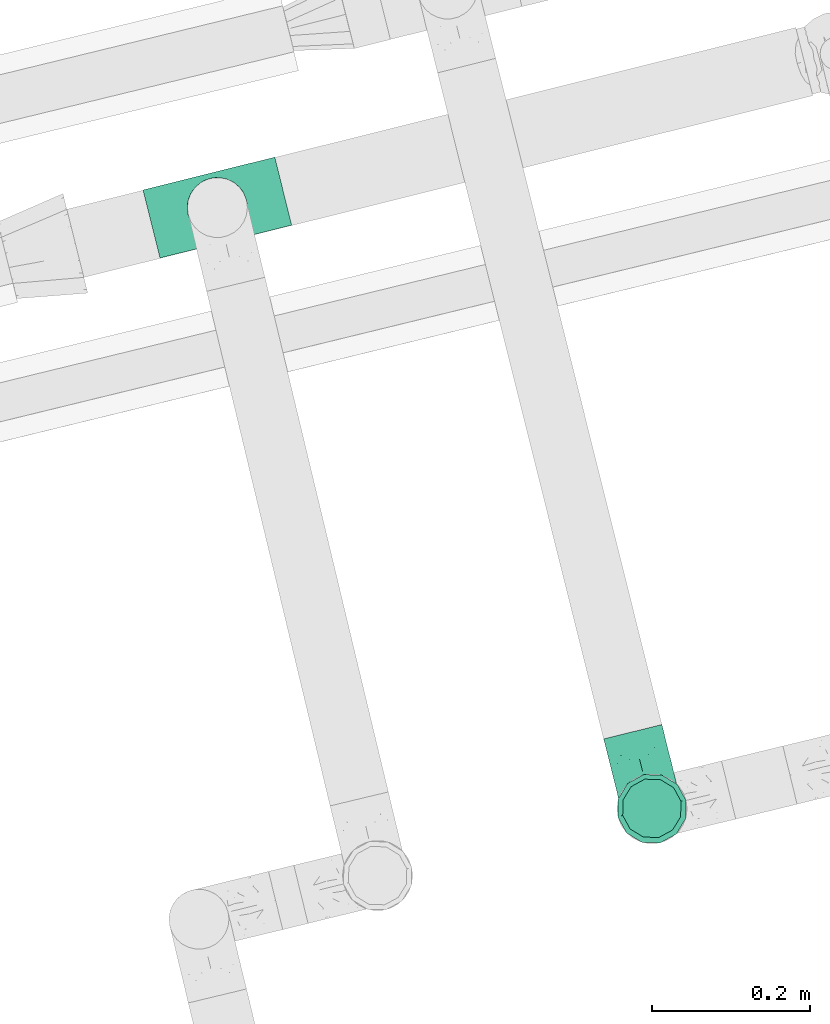
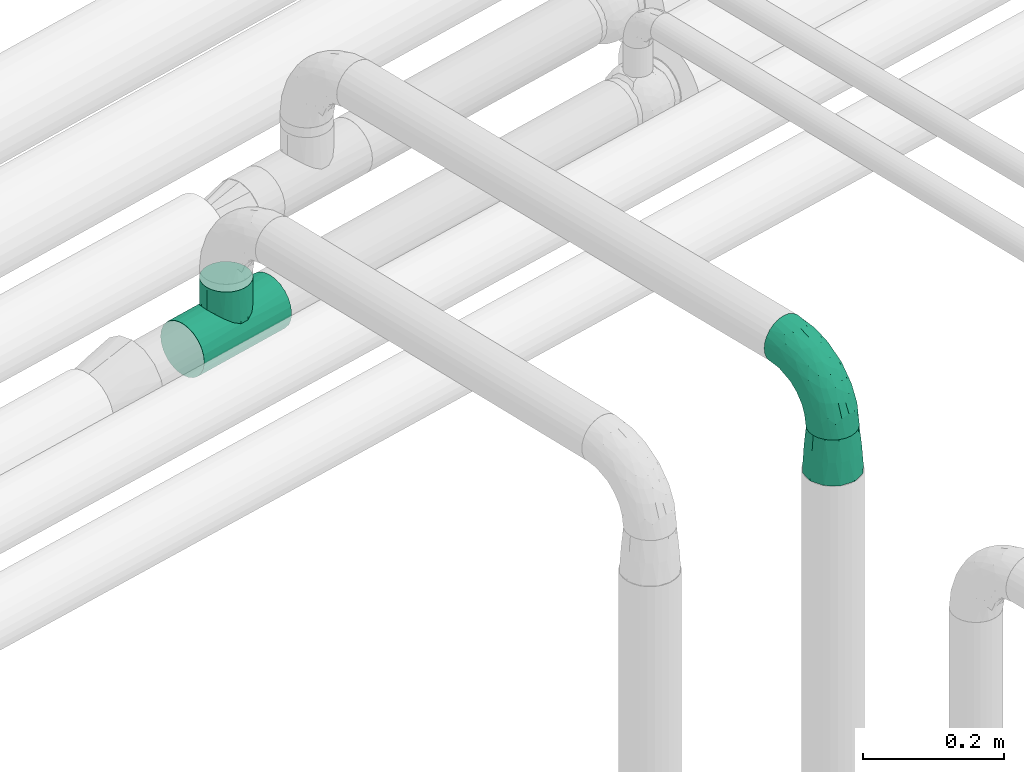
# One storey, part 86 of 93: 3 flow fittings.
"""IFC2X3 building model written with IfcOpenShell, lengths in millimetres."""

from ifc_helpers import new_model, entity, si_unit, converted_unit, derived_unit, direction, frame, origin, place, context, subcontext, project, spatial, faceted_brep, source, transform, mapped, material, type_object, type_shapes, element, save


model = new_model("IFC2X3")

# Units and contexts
model_context = context("Model", 3, precision=0.01, world=origin(), true_north=direction((6.12303176911189e-17, 1.0)))
body_context = subcontext(model_context, "Body", "Model", "MODEL_VIEW")
ifc_project = project(units=[si_unit("LENGTHUNIT", "METRE", prefix="MILLI"), si_unit("AREAUNIT", "SQUARE_METRE"), si_unit("VOLUMEUNIT", "CUBIC_METRE"), converted_unit("PLANEANGLEUNIT", "DEGREE", entity("IfcRatioMeasure", 0.0174532925199433), si_unit("PLANEANGLEUNIT", "RADIAN"), dimensions=[0, 0, 0, 0, 0, 0, 0]), si_unit("MASSUNIT", "GRAM", prefix="KILO"), derived_unit("MASSDENSITYUNIT", [(si_unit("MASSUNIT", "GRAM", prefix="KILO"), 1), (si_unit("LENGTHUNIT", "METRE"), -3)]), derived_unit("MOMENTOFINERTIAUNIT", [(si_unit("LENGTHUNIT", "METRE"), 4)]), si_unit("TIMEUNIT", "SECOND"), si_unit("FREQUENCYUNIT", "HERTZ"), si_unit("THERMODYNAMICTEMPERATUREUNIT", "DEGREE_CELSIUS"), derived_unit("THERMALTRANSMITTANCEUNIT", [(si_unit("MASSUNIT", "GRAM", prefix="KILO"), 1), (si_unit("THERMODYNAMICTEMPERATUREUNIT", "KELVIN"), -1), (si_unit("TIMEUNIT", "SECOND"), -3)]), derived_unit("VOLUMETRICFLOWRATEUNIT", [(si_unit("LENGTHUNIT", "METRE"), 3), (si_unit("TIMEUNIT", "SECOND"), -1)]), derived_unit("MASSFLOWRATEUNIT", [(si_unit("MASSUNIT", "GRAM", prefix="KILO"), 1), (si_unit("TIMEUNIT", "SECOND"), -1)]), derived_unit("ROTATIONALFREQUENCYUNIT", [(si_unit("TIMEUNIT", "SECOND"), -1)]), si_unit("ELECTRICCURRENTUNIT", "AMPERE"), si_unit("ELECTRICVOLTAGEUNIT", "VOLT"), si_unit("POWERUNIT", "WATT"), si_unit("FORCEUNIT", "NEWTON", prefix="KILO"), si_unit("ILLUMINANCEUNIT", "LUX"), si_unit("LUMINOUSFLUXUNIT", "LUMEN"), si_unit("LUMINOUSINTENSITYUNIT", "CANDELA"), derived_unit("USERDEFINED", [(si_unit("MASSUNIT", "GRAM", prefix="KILO"), -1), (si_unit("LENGTHUNIT", "METRE"), -2), (si_unit("TIMEUNIT", "SECOND"), 3), (si_unit("LUMINOUSFLUXUNIT", "LUMEN"), 1)]), derived_unit("LINEARVELOCITYUNIT", [(si_unit("LENGTHUNIT", "METRE"), 1), (si_unit("TIMEUNIT", "SECOND"), -1)]), si_unit("PRESSUREUNIT", "PASCAL"), derived_unit("USERDEFINED", [(si_unit("LENGTHUNIT", "METRE"), -2), (si_unit("MASSUNIT", "GRAM", prefix="KILO"), 1), (si_unit("TIMEUNIT", "SECOND"), -2)]), derived_unit("LINEARFORCEUNIT", [(si_unit("MASSUNIT", "GRAM", prefix="KILO"), 1), (si_unit("LENGTHUNIT", "METRE"), 1), (si_unit("TIMEUNIT", "SECOND"), -2), (si_unit("LENGTHUNIT", "METRE"), -1)]), derived_unit("PLANARFORCEUNIT", [(si_unit("MASSUNIT", "GRAM", prefix="KILO"), 1), (si_unit("LENGTHUNIT", "METRE"), 1), (si_unit("TIMEUNIT", "SECOND"), -2), (si_unit("LENGTHUNIT", "METRE"), -2)])], contexts=[model_context])

# Site, building, storey
site_placement = place(None, origin())
site = spatial("IfcSite", under=ifc_project, at=site_placement, CompositionType="ELEMENT")
building_placement = place(site_placement, origin())
building = spatial("IfcBuilding", under=site, at=building_placement, CompositionType="ELEMENT")
storey_placement = place(building_placement, frame((0.0, 0.0, -4200.0)))
storey = spatial("IfcBuildingStorey", under=building, at=storey_placement, CompositionType="ELEMENT", Elevation=-4200.0)

# Flow fittings
ifc_material = material()
pipe_fitting_type_1 = type_object("IfcPipeFittingType", Name="ADSK_2", PredefinedType="NOTDEFINED", material=ifc_material)
shared_shape_1 = source(origin(), body_context, "Body", "Brep", [
    faceted_brep([(-100.0, 19.0, -32.91), (-100.0, 9.84, -36.71), (-100.0, 0.0, -38.0), (-100.0, -9.84, -36.71), (-100.0, -19.0, -32.91), (-100.0, -26.87, -26.87), (-100.0, -32.91, -19.0), (-100.0, -36.71, -9.84), (-100.0, -38.0, 0.0), (-100.0, -36.71, 9.84), (-100.0, -32.91, 19.0), (-100.0, -26.87, 26.87), (-100.0, -19.0, 32.91), (-100.0, -9.84, 36.71), (-100.0, 0.0, 38.0), (-100.0, 9.84, 36.71), (-100.0, 19.0, 32.91), (-100.0, 26.87, 26.87), (-100.0, 32.91, 19.0), (-100.0, 36.71, 9.84), (-100.0, 38.0, 0.0), (-100.0, 36.71, -9.84), (-100.0, 32.91, -19.0), (-100.0, 26.87, -26.87), (-9.83, 100.0, -36.71), (-19.0, 100.0, -32.91), (-26.87, 100.0, -26.87), (-32.91, 100.0, -19.0), (-36.7, 100.0, -9.84), (-38.0, 100.0, 0.0), (-36.7, 100.0, 9.84), (-32.91, 100.0, 19.0), (-26.87, 100.0, 26.87), (-19.0, 100.0, 32.91), (-9.83, 100.0, 36.71), (0.0, 100.0, 38.0), (9.84, 100.0, 36.71), (19.0, 100.0, 32.91), (26.87, 100.0, 26.87), (32.91, 100.0, 19.0), (36.71, 100.0, 9.84), (38.0, 100.0, 0.0), (36.71, 100.0, -9.84), (32.91, 100.0, -19.0), (26.87, 100.0, -26.87), (19.0, 100.0, -32.91), (9.84, 100.0, -36.71), (0.0, 100.0, -38.0), (-40.69, 71.44, 16.62), (-81.22, -35.53, 0.0), (-67.52, -31.95, 12.5), (-8.97, -2.95, 6.59), (-11.71, -2.76, 13.62), (-24.68, -14.61, 8.04), (-64.28, -33.3, 0.0), (-83.72, 23.85, 30.89), (-76.19, 33.07, 24.6), (-74.12, -28.58, 21.76), (13.92, 43.47, 26.56), (5.03, 42.28, 32.41), (2.17, 22.78, 25.61), (20.11, 65.77, 28.71), (-65.77, -20.11, 28.71), (-74.23, -13.22, 34.41), (-44.44, -24.14, 12.16), (-47.64, -26.4, 0.0), (-31.0, -19.51, 0.0), (-54.86, 48.59, 21.12), (-81.55, 37.18, 15.86), (-42.28, -5.03, 32.41), (-52.67, 2.67, 37.1), (-14.76, 85.65, 35.5), (-6.46, 75.04, 37.87), (-58.38, 40.19, 26.6), (-15.88, 37.27, 37.68), (-29.21, 13.39, 36.1), (-10.53, 30.95, 35.7), (-77.78, -4.12, 37.45), (-2.67, 52.67, 37.1), (-76.41, 41.64, 8.45), (-71.15, 7.29, 37.89), (-32.26, 79.13, 24.41), (-44.28, 53.84, 26.08), (-25.18, 76.9, 31.2), (19.6, 43.38, 19.97), (6.25, 18.29, 16.9), (19.92, 34.73, 10.46), (-60.8, 50.97, 7.63), (-76.27, 42.72, 0.0), (-77.34, 15.98, 35.72), (-15.11, 15.11, 32.27), (-22.78, -2.17, 25.61), (28.58, 74.12, 21.76), (31.95, 67.52, 12.5), (-51.02, 30.39, 34.96), (-54.69, 20.06, 37.12), (26.4, 47.64, 0.0), (-51.15, 12.85, 38.0), (-32.84, 22.95, 37.94), (4.12, 77.78, 37.45), (-43.38, -19.6, 19.97), (35.53, 81.22, 0.0), (13.22, 74.23, 34.41), (-39.82, 82.33, 7.34), (-42.72, 76.27, 0.0), (-33.82, 52.47, 33.18), (-48.09, 40.81, 31.48), (-56.16, 56.16, 0.0), (-48.2, 64.18, 8.55), (-18.69, 66.93, 35.98), (-49.98, 57.58, 16.12), (-62.54, 46.99, 14.59), (-43.26, -12.84, 27.42), (-17.52, 48.72, 37.89), (-64.19, 29.4, 31.78), (-27.05, 50.9, 36.03), (-36.14, 36.14, 36.75), (-23.99, -8.71, 19.44), (6.3, 13.34, 7.98), (19.51, 31.0, 0.0), (-7.64, 6.3, 21.15), (-16.71, -8.55, 0.0), (33.3, 64.28, 0.0), (-2.42, 2.42, 0.0), (8.55, 16.71, 0.0), (-85.65, 14.76, -35.5), (-23.85, 83.72, -30.89), (-33.07, 76.19, -24.6), (-75.04, 6.46, -37.87), (-37.27, 15.88, -37.68), (-13.39, 29.21, -36.1), (-30.95, 10.53, -35.7), (-79.13, 32.26, -24.41), (-76.9, 25.18, -31.2), (6.3, 13.34, -7.98), (-11.71, -2.76, -13.62), (6.25, 18.29, -16.9), (-82.33, 39.82, -7.34), (-66.93, 18.69, -35.98), (-48.72, 17.52, -37.89), (-64.18, 48.2, -8.55), (31.95, 67.52, -12.5), (28.58, 74.12, -21.76), (-52.47, 33.83, -33.18), (4.12, 77.78, -37.45), (-7.29, 71.15, -37.89), (-15.98, 77.34, -35.72), (-67.52, -31.95, -12.5), (-30.39, 51.02, -34.96), (-20.06, 54.69, -37.12), (-48.59, 54.86, -21.12), (-37.18, 81.55, -15.86), (-74.12, -28.58, -21.76), (-29.4, 64.19, -31.78), (-40.81, 48.09, -31.48), (-40.19, 58.38, -26.6), (-65.77, -20.11, -28.71), (-74.23, -13.22, -34.41), (-39.81, -22.62, -10.22), (-77.78, -4.12, -37.45), (-43.38, -19.6, -19.97), (-12.85, 51.15, -38.0), (-22.95, 32.84, -37.94), (-71.44, 40.69, -16.62), (19.6, 43.38, -19.97), (20.11, 65.77, -28.71), (-52.67, 2.67, -37.1), (-53.84, 44.28, -26.08), (-41.64, 76.41, -8.45), (-23.99, -8.71, -19.44), (-43.47, -13.92, -26.56), (-22.78, -2.17, -25.61), (-20.59, -12.11, -6.83), (13.22, 74.23, -34.41), (5.03, 42.28, -32.41), (-2.67, 52.67, -37.1), (19.92, 34.73, -10.46), (-42.28, -5.03, -32.41), (12.84, 43.26, -27.42), (-50.97, 60.8, -7.63), (-57.58, 49.98, -16.12), (-46.99, 62.54, -14.59), (-50.9, 27.05, -36.03), (-36.14, 36.14, -36.75), (-15.11, 15.11, -32.27), (2.17, 22.78, -25.61), (-7.64, 6.3, -21.15), (-6.28, -0.33, -7.3)], [[[0, 1, 2, 3, 4, 5, 6, 7, 8, 9, 10, 11, 12, 13, 14, 15, 16, 17, 18, 19, 20, 21, 22, 23]], [[24, 25, 26, 27, 28, 29, 30, 31, 32, 33, 34, 35, 36, 37, 38, 39, 40, 41, 42, 43, 44, 45, 46, 47]], [[31, 30, 48]], [[49, 50, 9]], [[51, 52, 53]], [[9, 50, 10]], [[54, 50, 49]], [[17, 55, 56]], [[11, 10, 57]], [[58, 59, 60]], [[61, 38, 37]], [[62, 12, 11]], [[62, 63, 12]], [[64, 65, 66]], [[56, 67, 68]], [[63, 69, 70]], [[34, 71, 72]], [[67, 56, 73]], [[74, 75, 76]], [[16, 55, 17]], [[13, 77, 14]], [[76, 78, 74]], [[68, 79, 19]], [[18, 17, 56]], [[14, 77, 80]], [[20, 19, 79]], [[81, 82, 83]], [[84, 85, 86]], [[87, 88, 79]], [[18, 68, 19]], [[15, 89, 16]], [[14, 80, 15]], [[85, 84, 60]], [[90, 69, 91]], [[92, 84, 93]], [[94, 89, 95]], [[86, 96, 93]], [[83, 71, 33]], [[95, 97, 98]], [[36, 35, 99]], [[39, 38, 92]], [[39, 93, 40]], [[66, 53, 64]], [[92, 93, 39]], [[57, 100, 62]], [[93, 101, 40]], [[93, 84, 86]], [[61, 102, 59]], [[33, 32, 83]], [[103, 48, 30]], [[50, 57, 10]], [[104, 103, 29]], [[94, 105, 106]], [[104, 107, 108]], [[12, 63, 13]], [[83, 109, 71]], [[83, 105, 109]], [[32, 81, 83]], [[67, 110, 111]], [[108, 103, 104]], [[112, 69, 62]], [[33, 71, 34]], [[35, 34, 72]], [[109, 113, 72]], [[102, 37, 36]], [[102, 61, 37]], [[114, 106, 73]], [[89, 15, 80]], [[32, 31, 81]], [[115, 105, 116]], [[109, 115, 113]], [[99, 72, 78]], [[111, 87, 79]], [[108, 87, 110]], [[69, 63, 62]], [[77, 63, 70]], [[100, 117, 112]], [[69, 90, 75]], [[99, 102, 36]], [[78, 76, 59]], [[78, 59, 102]], [[59, 90, 60]], [[100, 57, 50]], [[62, 11, 57]], [[38, 61, 92]], [[84, 92, 61]], [[95, 89, 80]], [[55, 89, 114]], [[83, 82, 105]], [[94, 106, 114]], [[98, 113, 116]], [[78, 72, 113]], [[98, 116, 95]], [[98, 70, 75]], [[31, 48, 81]], [[82, 81, 48]], [[91, 112, 117]], [[60, 84, 58]], [[113, 115, 116]], [[118, 119, 86]], [[90, 91, 60]], [[91, 117, 120]], [[72, 99, 35]], [[102, 99, 78]], [[63, 77, 13]], [[80, 77, 70]], [[95, 80, 97]], [[94, 95, 116]], [[56, 68, 18]], [[79, 68, 111]], [[110, 87, 111]], [[79, 88, 20]], [[108, 107, 87]], [[88, 87, 107]], [[120, 60, 91]], [[66, 121, 53]], [[118, 86, 85]], [[122, 93, 96]], [[52, 118, 85]], [[118, 123, 124, 119]], [[48, 103, 108]], [[29, 103, 30]], [[89, 55, 16]], [[56, 55, 114]], [[80, 70, 97]], [[70, 98, 97]], [[105, 94, 116]], [[89, 94, 114]], [[105, 82, 106]], [[73, 106, 82]], [[67, 73, 82]], [[114, 73, 56]], [[110, 82, 48]], [[67, 111, 68]], [[82, 110, 67]], [[108, 110, 48]], [[69, 75, 70]], [[76, 75, 90]], [[59, 76, 90]], [[78, 113, 74]], [[113, 98, 74]], [[75, 74, 98]], [[9, 8, 49]], [[101, 93, 122]], [[101, 41, 40]], [[72, 71, 109]], [[50, 54, 65]], [[117, 53, 52]], [[109, 105, 115]], [[100, 112, 62]], [[91, 69, 112]], [[123, 51, 121]], [[120, 52, 85]], [[52, 120, 117]], [[60, 120, 85]], [[51, 118, 52]], [[100, 64, 117]], [[50, 64, 100]], [[121, 51, 53]], [[118, 51, 123]], [[84, 61, 58]], [[59, 58, 61]], [[86, 119, 96]], [[65, 64, 50]], [[117, 64, 53]], [[125, 1, 0]], [[26, 126, 127]], [[2, 1, 128]], [[129, 130, 131]], [[132, 133, 23]], [[134, 135, 136]], [[88, 137, 20]], [[138, 139, 128]], [[88, 107, 140]], [[141, 142, 43]], [[138, 133, 143]], [[47, 144, 145]], [[146, 24, 145]], [[125, 133, 138]], [[6, 147, 7]], [[148, 146, 149]], [[147, 49, 7]], [[127, 150, 151]], [[147, 6, 152]], [[153, 154, 155]], [[156, 4, 157]], [[140, 137, 88]], [[47, 145, 24]], [[42, 41, 101]], [[65, 147, 158]], [[148, 143, 154]], [[159, 3, 2]], [[147, 152, 160]], [[149, 161, 162]], [[156, 5, 4]], [[137, 163, 21]], [[142, 164, 165]], [[131, 166, 129]], [[27, 151, 28]], [[167, 133, 132]], [[168, 29, 28]], [[169, 170, 171]], [[127, 27, 26]], [[150, 127, 155]], [[135, 172, 158]], [[25, 24, 146]], [[1, 125, 128]], [[22, 21, 163]], [[126, 26, 25]], [[151, 168, 28]], [[47, 46, 144]], [[44, 165, 45]], [[0, 23, 133]], [[173, 174, 175]], [[119, 134, 176]], [[142, 44, 43]], [[173, 45, 165]], [[141, 43, 42]], [[45, 173, 46]], [[141, 101, 122]], [[156, 157, 177]], [[157, 4, 3]], [[101, 141, 42]], [[178, 174, 165]], [[169, 160, 170]], [[6, 5, 152]], [[170, 177, 171]], [[158, 147, 160]], [[104, 168, 179]], [[141, 96, 176]], [[150, 180, 181]], [[23, 22, 132]], [[182, 143, 183]], [[138, 182, 139]], [[159, 128, 166]], [[181, 179, 168]], [[140, 179, 180]], [[159, 157, 3]], [[166, 131, 177]], [[166, 177, 157]], [[177, 184, 171]], [[174, 173, 165]], [[144, 173, 175]], [[178, 164, 185]], [[174, 184, 130]], [[5, 156, 152]], [[160, 152, 156]], [[164, 142, 141]], [[165, 44, 142]], [[149, 146, 145]], [[126, 146, 153]], [[133, 167, 143]], [[148, 154, 153]], [[162, 139, 183]], [[166, 128, 139]], [[162, 183, 149]], [[162, 175, 130]], [[22, 163, 132]], [[167, 132, 163]], [[174, 185, 184]], [[136, 176, 134]], [[185, 136, 186]], [[158, 172, 66]], [[136, 185, 164]], [[171, 184, 185]], [[128, 159, 2]], [[157, 159, 166]], [[173, 144, 46]], [[145, 144, 175]], [[149, 145, 161]], [[148, 149, 183]], [[127, 151, 27]], [[168, 151, 181]], [[180, 179, 181]], [[168, 104, 29]], [[140, 107, 179]], [[104, 179, 107]], [[176, 136, 164]], [[135, 169, 186]], [[141, 176, 164]], [[134, 119, 124, 123]], [[158, 66, 65]], [[187, 172, 135]], [[163, 137, 140]], [[20, 137, 21]], [[146, 126, 25]], [[127, 126, 153]], [[145, 175, 161]], [[175, 162, 161]], [[143, 148, 183]], [[146, 148, 153]], [[143, 167, 154]], [[155, 154, 167]], [[150, 155, 167]], [[153, 155, 127]], [[180, 167, 163]], [[150, 181, 151]], [[167, 180, 150]], [[140, 180, 163]], [[174, 130, 175]], [[131, 130, 184]], [[177, 131, 184]], [[166, 139, 129]], [[139, 162, 129]], [[130, 129, 162]], [[49, 147, 54]], [[49, 8, 7]], [[133, 125, 0]], [[128, 125, 138]], [[158, 160, 169]], [[65, 54, 147]], [[187, 135, 134]], [[187, 121, 172]], [[134, 123, 187]], [[139, 182, 183]], [[121, 187, 123]], [[121, 66, 172]], [[138, 143, 182]], [[160, 156, 170]], [[177, 170, 156]], [[186, 169, 171]], [[158, 169, 135]], [[185, 186, 171]], [[135, 186, 136]], [[164, 178, 165]], [[185, 174, 178]], [[96, 141, 122]], [[96, 119, 176]]]),
])
type_shapes(pipe_fitting_type_1, [shared_shape_1])
flow_fitting_1_placement = place(storey_placement, frame((-11078.14, 11576.98, 2700.0), z_axis=(-0.970288704798105, -0.241950055468513, 0.0), x_axis=(0.0, 0.0, 1.0)))
element("IfcFlowFitting", 1, at=flow_fitting_1_placement, inside=storey, type_object=pipe_fitting_type_1, material=ifc_material, Name="ADSK_2", ObjectType="ADSK_2", context=body_context, shape_type="MappedRepresentation", body=[
    mapped(shared_shape_1, transform((0.0, 0.0, 0.0), scale=1.0)),
])
pipe_fitting_type_2 = type_object("IfcPipeFittingType", Name="ADSK_2", PredefinedType="NOTDEFINED", material=ifc_material)
shared_shape_2 = source(origin(), body_context, "Body", "Brep", [
    faceted_brep([(75.0, 32.91, 18.45), (75.0, 25.95, 25.41), (75.0, 19.0, 32.36), (75.0, 9.5, 34.91), (75.0, 0.0, 37.45), (75.0, -9.5, 34.91), (75.0, -19.0, 32.36), (75.0, -25.95, 25.41), (75.0, -32.91, 18.45), (75.0, -35.45, 8.95), (75.0, -38.0, -0.55), (75.0, -35.45, -10.05), (75.0, -32.91, -19.55), (75.0, -25.95, -26.5), (75.0, -19.0, -33.46), (75.0, -9.5, -36.0), (75.0, 0.0, -38.55), (75.0, 9.5, -36.0), (75.0, 19.0, -33.46), (75.0, 25.95, -26.5), (75.0, 32.91, -19.55), (75.0, 35.45, -10.05), (75.0, 38.0, -0.55), (75.0, 35.45, 8.95), (0.0, -38.54, 22.25), (0.0, -30.39, 30.39), (0.0, -22.25, 38.54), (0.0, -11.12, 41.52), (0.0, 0.0, 44.5), (0.0, 11.13, 41.52), (0.0, 22.25, 38.54), (0.0, 30.39, 30.39), (0.0, 38.54, 22.25), (0.0, 41.52, 11.13), (0.0, 44.5, 0.0), (0.0, 41.52, -11.13), (0.0, 38.54, -22.25), (0.0, 30.39, -30.39), (0.0, 22.25, -38.54), (0.0, 11.12, -41.52), (0.0, 0.0, -44.5), (0.0, -11.13, -41.52), (0.0, -22.25, -38.54), (0.0, -30.39, -30.39), (0.0, -38.54, -22.25), (0.0, -41.52, -11.12), (0.0, -44.5, 0.0), (0.0, -41.52, 11.13), (37.5, -32.73, -25.39), (37.5, -25.11, -33.0), (37.5, -5.38, -41.17), (37.5, -17.77, -37.5), (37.5, -37.23, -18.05), (37.5, -39.96, -10.53), (37.5, 32.73, -25.39), (49.22, -40.23, -0.36), (49.22, 40.23, -0.36), (37.5, 3.22, -41.4), (37.5, 15.79, -38.38), (37.5, 23.35, -34.28), (37.5, 37.23, -18.05), (37.5, 39.96, -10.53), (37.5, 32.73, 24.84), (37.5, 25.11, 32.45), (37.5, 5.38, 40.62), (37.5, 17.77, 36.95), (37.5, 37.23, 17.5), (37.5, 39.96, 9.98), (37.5, -32.73, 24.84), (37.5, -3.22, 40.85), (37.5, -15.79, 37.84), (37.5, -23.35, 33.73), (37.5, -37.23, 17.5), (37.5, -39.96, 9.98)], [[[0, 1, 2, 3, 4, 5, 6, 7, 8, 9, 10, 11, 12, 13, 14, 15, 16, 17, 18, 19, 20, 21, 22, 23]], [[24, 25, 26, 27, 28, 29, 30, 31, 32, 33, 34, 35, 36, 37, 38, 39, 40, 41, 42, 43, 44, 45, 46, 47]], [[48, 49, 13]], [[50, 15, 51]], [[49, 43, 42]], [[52, 11, 53]], [[12, 52, 48]], [[52, 44, 48]], [[51, 49, 42]], [[12, 48, 13]], [[51, 14, 49]], [[49, 48, 43]], [[50, 41, 40]], [[44, 43, 48]], [[36, 54, 37]], [[45, 44, 52]], [[55, 11, 10]], [[21, 56, 22]], [[57, 16, 50]], [[58, 39, 38]], [[53, 45, 52]], [[58, 59, 18]], [[60, 20, 54]], [[53, 46, 45]], [[52, 12, 11]], [[50, 51, 41]], [[51, 42, 41]], [[13, 49, 14]], [[15, 14, 51]], [[57, 50, 40]], [[15, 50, 16]], [[59, 58, 38]], [[58, 57, 39]], [[57, 40, 39]], [[58, 17, 57]], [[17, 16, 57]], [[17, 58, 18]], [[60, 54, 36]], [[54, 59, 37]], [[59, 38, 37]], [[54, 19, 59]], [[19, 18, 59]], [[19, 54, 20]], [[61, 21, 60]], [[60, 35, 61]], [[60, 36, 35]], [[11, 55, 53]], [[21, 20, 60]], [[34, 56, 61]], [[46, 53, 55]], [[34, 61, 35]], [[56, 21, 61]], [[62, 63, 1]], [[64, 3, 65]], [[63, 31, 30]], [[66, 23, 67]], [[0, 66, 62]], [[66, 32, 62]], [[65, 63, 30]], [[0, 62, 1]], [[65, 2, 63]], [[63, 62, 31]], [[64, 29, 28]], [[32, 31, 62]], [[24, 68, 25]], [[33, 32, 66]], [[56, 23, 22]], [[9, 55, 10]], [[69, 4, 64]], [[70, 27, 26]], [[67, 33, 66]], [[70, 71, 6]], [[72, 8, 68]], [[67, 34, 33]], [[66, 0, 23]], [[64, 65, 29]], [[65, 30, 29]], [[1, 63, 2]], [[3, 2, 65]], [[69, 64, 28]], [[3, 64, 4]], [[71, 70, 26]], [[70, 69, 27]], [[69, 28, 27]], [[70, 5, 69]], [[5, 4, 69]], [[5, 70, 6]], [[72, 68, 24]], [[68, 71, 25]], [[71, 26, 25]], [[68, 7, 71]], [[7, 6, 71]], [[7, 68, 8]], [[73, 9, 72]], [[72, 47, 73]], [[72, 24, 47]], [[23, 56, 67]], [[9, 8, 72]], [[46, 55, 73]], [[34, 67, 56]], [[46, 73, 47]], [[55, 9, 73]]]),
])
type_shapes(pipe_fitting_type_2, [shared_shape_2])
flow_fitting_2_placement = place(storey_placement, frame((-11078.01, 11576.44, 2525.0), z_axis=(0.236820736662412, -0.971553363787431, 0.0), x_axis=(0.0, 0.0, 1.0)))
element("IfcFlowFitting", 2, at=flow_fitting_2_placement, inside=storey, type_object=pipe_fitting_type_2, material=ifc_material, Name="ADSK_2", ObjectType="ADSK_2", context=body_context, shape_type="MappedRepresentation", body=[
    mapped(shared_shape_2, transform((0.0, 0.0, 0.0), scale=1.0)),
])
pipe_fitting_type_3 = type_object("IfcPipeFittingType", Name="ADSK_1", PredefinedType="NOTDEFINED", material=ifc_material)
shared_shape_3 = source(origin(), body_context, "Body", "Brep", [
    faceted_brep([(-86.0, 22.22, -38.49), (-86.0, 11.5, -42.94), (-86.0, 0.0, -44.45), (-86.0, -11.5, -42.94), (-86.0, -22.23, -38.49), (-86.0, -31.43, -31.43), (-86.0, -34.96, -26.83), (-86.0, -38.49, -22.23), (-86.0, -40.72, -16.86), (-86.0, -42.94, -11.5), (-86.0, -43.69, -5.75), (-86.0, -44.45, 0.0), (-86.0, -43.69, 5.75), (-86.0, -42.94, 11.5), (-86.0, -40.72, 16.86), (-86.0, -38.49, 22.22), (-86.0, -34.96, 26.83), (-86.0, -31.43, 31.43), (-86.0, -22.23, 38.49), (-86.0, -11.5, 42.94), (-86.0, 0.0, 44.45), (-86.0, 11.5, 42.94), (-86.0, 22.22, 38.49), (-86.0, 31.43, 31.43), (-86.0, 38.49, 22.22), (-86.0, 42.94, 11.5), (-86.0, 44.45, 0.0), (-86.0, 42.94, -11.5), (-86.0, 38.49, -22.23), (-86.0, 31.43, -31.43), (86.0, 0.0, -44.45), (86.0, 11.5, -42.94), (86.0, 22.22, -38.49), (86.0, 31.43, -31.43), (86.0, 38.49, -22.23), (86.0, 42.94, -11.5), (86.0, 44.45, 0.0), (86.0, 42.94, 11.5), (86.0, 38.49, 22.22), (86.0, 31.43, 31.43), (86.0, 22.22, 38.49), (86.0, 11.5, 42.94), (86.0, 0.0, 44.45), (86.0, -11.5, 42.94), (86.0, -22.23, 38.49), (86.0, -31.43, 31.43), (86.0, -34.96, 26.83), (86.0, -38.49, 22.22), (86.0, -40.72, 16.86), (86.0, -42.94, 11.5), (86.0, -43.69, 5.75), (86.0, -44.45, 0.0), (86.0, -43.69, -5.75), (86.0, -42.94, -11.5), (86.0, -40.72, -16.86), (86.0, -38.49, -22.23), (86.0, -34.96, -26.83), (86.0, -31.43, -31.43), (86.0, -22.23, -38.49), (86.0, -11.5, -42.94), (36.76, -43.36, 6.88), (35.48, -42.27, 13.75), (32.1, -39.52, 19.36), (38.05, -44.45, 0.0), (-38.05, -44.45, 0.0), (19.13, -29.9, 32.89), (-35.48, -42.27, 13.74), (-32.1, -39.52, 19.35), (28.71, -36.78, 24.97), (7.0, -24.02, 37.4), (-19.13, -29.9, 32.89), (-28.71, -36.78, 24.97), (-36.77, -43.36, 6.87), (-7.02, -24.03, 37.4), (-0.01, -24.02, 37.4), (36.76, -43.36, -6.88), (7.0, -24.02, -37.4), (-32.1, -39.52, -19.35), (-36.77, -43.36, -6.87), (-7.02, -24.03, -37.4), (19.13, -29.9, -32.89), (28.71, -36.78, -24.97), (-35.48, -42.27, -13.74), (32.1, -39.52, -19.36), (35.48, -42.27, -13.75), (-19.13, -29.9, -32.89), (-28.71, -36.78, -24.97), (-0.01, -24.02, -37.4), (9.85, -83.0, -36.75), (19.03, -83.0, -32.95), (26.91, -83.0, -26.91), (32.95, -83.0, -19.03), (36.75, -83.0, -9.85), (38.05, -83.0, 0.0), (36.75, -83.0, 9.85), (32.95, -83.0, 19.02), (26.91, -83.0, 26.91), (19.03, -83.0, 32.95), (9.85, -83.0, 36.75), (0.0, -83.0, 38.05), (-9.85, -83.0, 36.75), (-19.02, -83.0, 32.95), (-26.91, -83.0, 26.91), (-32.95, -83.0, 19.02), (-36.75, -83.0, 9.85), (-38.05, -83.0, 0.0), (-36.75, -83.0, -9.85), (-32.95, -83.0, -19.03), (-26.91, -83.0, -26.91), (-19.02, -83.0, -32.95), (-9.85, -83.0, -36.75), (0.0, -83.0, -38.05)], [[[0, 1, 2, 3, 4, 5, 6, 7, 8, 9, 10, 11, 12, 13, 14, 15, 16, 17, 18, 19, 20, 21, 22, 23, 24, 25, 26, 27, 28, 29]], [[30, 31, 32, 33, 34, 35, 36, 37, 38, 39, 40, 41, 42, 43, 44, 45, 46, 47, 48, 49, 50, 51, 52, 53, 54, 55, 56, 57, 58, 59]], [[49, 60, 50]], [[61, 48, 62]], [[51, 50, 63]], [[64, 12, 11]], [[47, 62, 48]], [[45, 65, 46]], [[14, 66, 67]], [[68, 46, 65]], [[44, 69, 65]], [[47, 68, 62]], [[65, 45, 44]], [[61, 49, 48]], [[70, 16, 71]], [[72, 66, 13]], [[68, 47, 46]], [[72, 13, 12]], [[64, 72, 12]], [[66, 14, 13]], [[63, 50, 60]], [[17, 70, 18]], [[15, 71, 16]], [[14, 67, 15]], [[16, 70, 17]], [[70, 73, 18]], [[49, 61, 60]], [[15, 67, 71]], [[19, 73, 74, 69]], [[20, 19, 43, 42]], [[69, 43, 19]], [[21, 20, 42, 41]], [[38, 37, 25, 24]], [[23, 22, 40, 39]], [[24, 23, 39, 38]], [[41, 40, 22, 21]], [[26, 25, 37, 36]], [[73, 19, 18]], [[69, 44, 43]], [[35, 34, 28, 27]], [[75, 53, 52]], [[34, 33, 29, 28]], [[36, 35, 27, 26]], [[30, 59, 3, 2]], [[1, 0, 32, 31]], [[2, 1, 31, 30]], [[33, 32, 0, 29]], [[59, 76, 3]], [[7, 77, 8]], [[64, 10, 78]], [[79, 4, 3]], [[59, 58, 76]], [[56, 80, 57]], [[81, 56, 55]], [[82, 9, 8]], [[76, 58, 80]], [[55, 83, 81]], [[80, 58, 57]], [[63, 75, 52]], [[53, 84, 54]], [[84, 53, 75]], [[63, 52, 51]], [[11, 10, 64]], [[83, 55, 54]], [[9, 82, 78]], [[85, 5, 4]], [[86, 7, 6]], [[85, 6, 5]], [[6, 85, 86]], [[80, 56, 81]], [[85, 4, 79]], [[54, 84, 83]], [[7, 86, 77]], [[78, 10, 9]], [[8, 77, 82]], [[3, 76, 87, 79]], [[88, 89, 90, 91, 92, 93, 94, 95, 96, 97, 98, 99, 100, 101, 102, 103, 104, 105, 106, 107, 108, 109, 110, 111]], [[66, 104, 103]], [[70, 102, 101]], [[103, 102, 71]], [[70, 101, 100]], [[72, 105, 104]], [[64, 105, 72]], [[104, 66, 72]], [[103, 71, 67, 66]], [[102, 70, 71]], [[60, 93, 63]], [[100, 73, 70]], [[99, 69, 74, 73]], [[65, 98, 97]], [[96, 65, 97]], [[61, 95, 94]], [[96, 95, 68]], [[69, 99, 98]], [[98, 65, 69]], [[99, 73, 100]], [[65, 96, 68]], [[95, 61, 62, 68]], [[60, 61, 94]], [[93, 60, 94]], [[92, 75, 93]], [[78, 82, 106]], [[111, 76, 88]], [[78, 105, 64]], [[92, 84, 75]], [[92, 91, 84]], [[90, 81, 91]], [[75, 63, 93]], [[91, 81, 83, 84]], [[89, 88, 80]], [[80, 81, 90]], [[80, 88, 76]], [[80, 90, 89]], [[111, 79, 87, 76]], [[85, 110, 109]], [[108, 85, 109]], [[82, 107, 106]], [[108, 107, 86]], [[79, 111, 110]], [[110, 85, 79]], [[85, 108, 86]], [[107, 82, 77, 86]], [[105, 78, 106]]]),
])
type_shapes(pipe_fitting_type_3, [shared_shape_3])
flow_fitting_3_placement = place(storey_placement, frame((-11628.72, 12338.23, 2503.64), z_axis=(-0.24189419226589, 0.970302633072812, 0.0), x_axis=(0.970302633072812, 0.24189419226589, 0.0)))
element("IfcFlowFitting", 3, at=flow_fitting_3_placement, inside=storey, type_object=pipe_fitting_type_3, material=ifc_material, Name="ADSK_1", ObjectType="ADSK_1", context=body_context, shape_type="MappedRepresentation", body=[
    mapped(shared_shape_3, transform((0.0, 0.0, 0.0), scale=1.0)),
])

save(model, "model.ifc")
